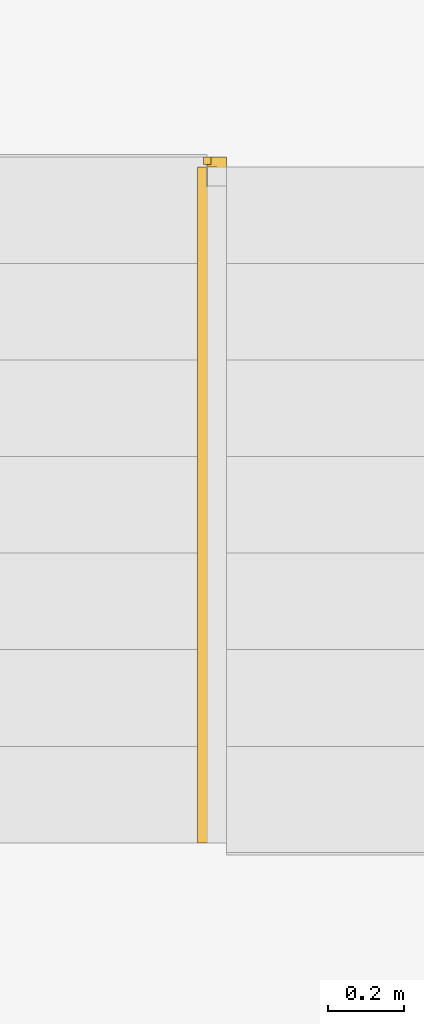
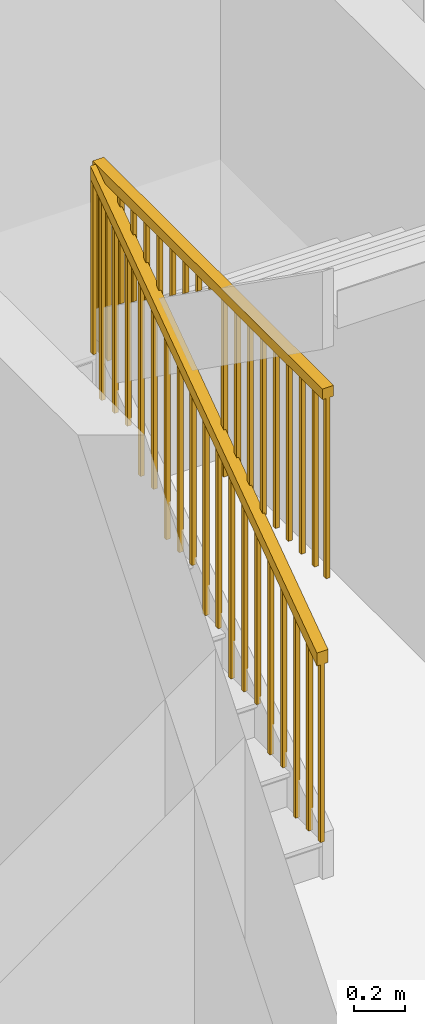
# One storey, part 5 of 6: 2 railings, 1 element without a shape of its own.
"""IFC2X3 building model written with IfcOpenShell, lengths in feet."""

import ifcopenshell
import ifcopenshell.guid

model = None  # the IFC model being written
_history = None  # IfcOwnerHistory: only IFC2X3 demands one
_inside = {}  # id of a spatial element -> (the spatial element, [elements in it])
_under = {}  # id of a project, library or spatial element -> (it, [spatial elements below it])
_declared = {}  # id of a project -> (the project, [libraries it declares])
_typed = {}  # id of a type object -> (the type object, [elements of that type])
_made_of = {}  # id of a material, layer set ... -> (it, [elements and type objects made of it])


def new_model(schema):
    """Start an empty IFC model of exactly this schema.

    Asked for "IFC4X3", IfcOpenShell would pick the latest addendum, in which some entities
    have other attributes; the version numbers below select the first issue.
    IFC2X3 requires an IfcOwnerHistory on every rooted entity: one is made here for all.
    """
    global model, _history
    if schema == "IFC4X3":
        model = ifcopenshell.file(schema_version=(4, 3, 0, 0))
    else:
        model = ifcopenshell.file(schema=schema)
    _inside.clear()
    _under.clear()
    _declared.clear()
    _typed.clear()
    _made_of.clear()
    _history = None
    if model.schema == "IFC2X3":
        org = make("IfcOrganization", Name="unknown")
        user = make(
            "IfcPersonAndOrganization",
            ThePerson=make("IfcPerson", FamilyName="unknown"),
            TheOrganization=org,
        )
        app = make(
            "IfcApplication",
            ApplicationDeveloper=org,
            Version="unknown",
            ApplicationFullName="unknown",
            ApplicationIdentifier="unknown",
        )
        _history = make(
            "IfcOwnerHistory",
            OwningUser=user,
            OwningApplication=app,
            ChangeAction="ADDED",
            CreationDate=0,
        )
    return model


def make(cls, **values):
    """One entity of the class cls with the attributes given. An attribute that is None is left unset."""
    return model.create_entity(
        cls, **{name: value for name, value in values.items() if value is not None}
    )


def entity(cls, *values):
    """Any entity or typed value of the class cls, its attributes in the order of the schema. None: left unset."""
    e = model.create_entity(cls)
    for i, value in enumerate(values):
        if value is not None:
            e[i] = value
    return e


def rooted(cls, **values):
    """An entity with a GlobalId (a new one), such as an element, a storey or a relation."""
    return make(cls, GlobalId=ifcopenshell.guid.new(), OwnerHistory=_history, **values)


def si_unit(unit_type, name, prefix=None):
    """IfcSIUnit, for example si_unit("LENGTHUNIT", "METRE", prefix="MILLI")."""
    return make("IfcSIUnit", UnitType=unit_type, Prefix=prefix, Name=name)


def converted_unit(unit_type, name, factor, base, dimensions=None, offset=None):
    """IfcConversionBasedUnit, such as the inch: factor (a typed value) times the base unit."""
    return make(
        "IfcConversionBasedUnit"
        if offset is None
        else "IfcConversionBasedUnitWithOffset",
        ConversionOffset=offset,
        Dimensions=None
        if dimensions is None
        else entity("IfcDimensionalExponents", *dimensions),
        UnitType=unit_type,
        Name=name,
        ConversionFactor=make(
            "IfcMeasureWithUnit", ValueComponent=factor, UnitComponent=base
        ),
    )


def derived_unit(unit_type, elements):
    """IfcDerivedUnit: a product of units, each with its exponent."""
    return make(
        "IfcDerivedUnit",
        Elements=[
            make("IfcDerivedUnitElement", Unit=unit, Exponent=power)
            for unit, power in elements
        ],
        UnitType=unit_type,
    )


def assignment(units):
    """IfcUnitAssignment: the units of a project."""
    return None if units is None else make("IfcUnitAssignment", Units=units)


def point(xyz):
    """IfcCartesianPoint."""
    return None if xyz is None else make("IfcCartesianPoint", Coordinates=xyz)


def direction(xyz):
    """IfcDirection."""
    return None if xyz is None else make("IfcDirection", DirectionRatios=xyz)


def frame(location, z_axis=None, x_axis=None):
    """IfcAxis2Placement3D, a coordinate frame: its origin and axes. An axis left out is left unset."""
    return make(
        "IfcAxis2Placement3D",
        Location=point(location),
        Axis=direction(z_axis),
        RefDirection=direction(x_axis),
    )


def frame_2d(location, x_axis=None):
    """IfcAxis2Placement2D, a coordinate frame in the plane: its origin and x axis."""
    return make(
        "IfcAxis2Placement2D", Location=point(location), RefDirection=direction(x_axis)
    )


def origin():
    """The frame at (0, 0, 0) with its axes left unset."""
    return frame((0.0, 0.0, 0.0))


def origin_2d_with_axis():
    """The frame at (0, 0) in the plane with the x axis (1, 0) written out."""
    return frame_2d((0.0, 0.0), x_axis=(1.0, 0.0))


def place(relative_to, where):
    """IfcLocalPlacement: puts the frame where relative to a parent placement (None: the world)."""
    return make(
        "IfcLocalPlacement", PlacementRelTo=relative_to, RelativePlacement=where
    )


def context(
    kind, dimensions, precision=None, world=None, true_north=None, identifier=None
):
    """IfcGeometricRepresentationContext, for example the 3D "Model" context."""
    return make(
        "IfcGeometricRepresentationContext",
        ContextIdentifier=identifier,
        ContextType=kind,
        CoordinateSpaceDimension=dimensions,
        Precision=precision,
        WorldCoordinateSystem=world,
        TrueNorth=true_north,
    )


def subcontext(parent, identifier, kind, view, scale=None):
    """IfcGeometricRepresentationSubContext, for example "Body" below "Model"."""
    return make(
        "IfcGeometricRepresentationSubContext",
        ContextIdentifier=identifier,
        ContextType=kind,
        ParentContext=parent,
        TargetScale=scale,
        TargetView=view,
    )


def project(units=None, contexts=None):
    """IfcProject with its units and contexts."""
    return rooted(
        "IfcProject",
        Name="project",
        RepresentationContexts=contexts,
        UnitsInContext=assignment(units),
    )


def spatial(cls, under=None, at=None, **own):
    """A site, building, storey or space (cls), placed at a placement, below another one or the project."""
    s = rooted(cls, ObjectPlacement=at, **own)
    if under is not None:
        _under.setdefault(under.id(), (under, []))[1].append(s)
    return s


def polyline(points):
    """IfcPolyline through the points."""
    return make("IfcPolyline", Points=[point(p) for p in points])


def profile(cls, at=None, kind="AREA", **sizes):
    """A parametric profile (cls). Its sizes go by their IFC names, for example OverallWidth=200.0."""
    return make(cls, ProfileType=kind, Position=at, **sizes)


def rectangle(**sizes):
    """IfcRectangleProfileDef."""
    return profile("IfcRectangleProfileDef", **sizes)


def outline(outer, holes=None, kind="AREA"):
    """IfcArbitraryClosedProfileDef: a profile drawn as a closed curve; with holes, ...WithVoids."""
    if holes is None:
        return make("IfcArbitraryClosedProfileDef", ProfileType=kind, OuterCurve=outer)
    return make(
        "IfcArbitraryProfileDefWithVoids",
        ProfileType=kind,
        OuterCurve=outer,
        InnerCurves=holes,
    )


def extrude(swept, where, along, depth):
    """IfcExtrudedAreaSolid: the profile swept, set in the frame where, extruded along a direction by depth."""
    return make(
        "IfcExtrudedAreaSolid",
        SweptArea=swept,
        Position=where,
        ExtrudedDirection=direction(along),
        Depth=depth,
    )


def shape(context_of_items, identifier, shape_type, items):
    """IfcShapeRepresentation: the items that make up one representation, for example the "Body"."""
    return make(
        "IfcShapeRepresentation",
        ContextOfItems=context_of_items,
        RepresentationIdentifier=identifier,
        RepresentationType=shape_type,
        Items=items,
    )


def material(Name=None, Category=None):
    """IfcMaterial."""
    return make("IfcMaterial", Name=Name, Category=Category)


def made_of(thing, what):
    """Note that an element or type object is made of a material, layer set ...; save() writes the relation."""
    if what is not None:
        _made_of.setdefault(what.id(), (what, []))[1].append(thing)
    return thing


def type_object(cls, material=None, **own):
    """A type object (cls), such as IfcWallType, which elements share."""
    return made_of(rooted(cls, **own), material)


def element(
    cls,
    number,
    at=None,
    inside=None,
    cuts=None,
    type_object=None,
    material=None,
    context=None,
    identifier="Body",
    shape_type=None,
    held_by="IfcProductDefinitionShape",
    body=None,
    shapes=None,
    **own,
):
    """One element of the class cls, such as IfcWall. Its Tag is "e" and its number.

    at: its placement. inside: the storey or other place that contains it. cuts: it is an
    opening in that element (IfcRelVoidsElement). A single representation is given by context,
    identifier, shape_type and body (its items); several are given by shapes. held_by: the class
    of the entity that holds the representations. save() writes the other relations.
    """
    e = rooted(cls, Tag="e%d" % number, ObjectPlacement=at, **own)
    if body is not None:
        shapes = [shape(context, identifier, shape_type, body)]
    if shapes is not None:
        e.Representation = make(held_by, Representations=shapes)
    if inside is not None:
        _inside.setdefault(inside.id(), (inside, []))[1].append(e)
    if cuts is not None:
        rooted(
            "IfcRelVoidsElement", RelatingBuildingElement=cuts, RelatedOpeningElement=e
        )
    if type_object is not None:
        _typed.setdefault(type_object.id(), (type_object, []))[1].append(e)
    return made_of(e, material)


def aggregate(whole, parts):
    """IfcRelAggregates: a whole, such as a stair, and the parts it consists of."""
    return rooted("IfcRelAggregates", RelatingObject=whole, RelatedObjects=parts)


def save(model, path):
    """Write the relations noted so far, then the file.

    IfcRelAggregates (storeys below a building ...), IfcRelContainedInSpatialStructure (elements
    in a storey), IfcRelDefinesByType, IfcRelAssociatesMaterial and IfcRelDeclares: one each for
    every whole, place, type object, material and project.
    """
    for whole, parts in _under.values():
        aggregate(whole, parts)
    for where, things in _inside.values():
        rooted(
            "IfcRelContainedInSpatialStructure",
            RelatedElements=things,
            RelatingStructure=where,
        )
    for kind, things in _typed.values():
        rooted("IfcRelDefinesByType", RelatedObjects=things, RelatingType=kind)
    for what, things in _made_of.values():
        rooted("IfcRelAssociatesMaterial", RelatedObjects=things, RelatingMaterial=what)
    for by, libraries in _declared.values():
        rooted("IfcRelDeclares", RelatingContext=by, RelatedDefinitions=libraries)
    model.write(path)


model = new_model("IFC2X3")

# Units and contexts
model_context = context("Model", 3, precision=0.0001, world=origin(), true_north=direction((6.123031769111886e-17, 1.0)))
body_context = subcontext(model_context, "Body", "Model", "MODEL_VIEW")
ifc_project = project(units=[converted_unit("LENGTHUNIT", "FOOT", entity("IfcLengthMeasure", 0.3048), si_unit("LENGTHUNIT", "METRE"), dimensions=[1, 0, 0, 0, 0, 0, 0]), converted_unit("AREAUNIT", "SQUARE FOOT", entity("IfcAreaMeasure", 0.09290304), si_unit("AREAUNIT", "SQUARE_METRE"), dimensions=[2, 0, 0, 0, 0, 0, 0]), converted_unit("VOLUMEUNIT", "CUBIC FOOT", entity("IfcVolumeMeasure", 0.028316846592000004), si_unit("VOLUMEUNIT", "CUBIC_METRE"), dimensions=[3, 0, 0, 0, 0, 0, 0]), converted_unit("PLANEANGLEUNIT", "DEGREE", entity("IfcPlaneAngleMeasure", 0.017453292519943278), si_unit("PLANEANGLEUNIT", "RADIAN"), dimensions=[0, 0, 0, 0, 0, 0, 0]), si_unit("MASSUNIT", "GRAM", prefix="KILO"), derived_unit("MASSDENSITYUNIT", [(si_unit("MASSUNIT", "GRAM", prefix="KILO"), 1), (si_unit("LENGTHUNIT", "METRE"), -3)]), derived_unit("IONCONCENTRATIONUNIT", [(si_unit("MASSUNIT", "GRAM", prefix="KILO"), 1), (si_unit("LENGTHUNIT", "METRE"), -3)]), derived_unit("MOMENTOFINERTIAUNIT", [(si_unit("LENGTHUNIT", "METRE"), 4)]), si_unit("TIMEUNIT", "SECOND"), si_unit("FREQUENCYUNIT", "HERTZ"), si_unit("THERMODYNAMICTEMPERATUREUNIT", "DEGREE_CELSIUS"), derived_unit("THERMALTRANSMITTANCEUNIT", [(si_unit("MASSUNIT", "GRAM", prefix="KILO"), 1), (si_unit("THERMODYNAMICTEMPERATUREUNIT", "KELVIN"), -1), (si_unit("TIMEUNIT", "SECOND"), -3)]), derived_unit("THERMALCONDUCTANCEUNIT", [(si_unit("MASSUNIT", "GRAM", prefix="KILO"), 1), (si_unit("THERMODYNAMICTEMPERATUREUNIT", "KELVIN"), -1), (si_unit("TIMEUNIT", "SECOND"), -3), (si_unit("LENGTHUNIT", "METRE"), 1)]), derived_unit("VOLUMETRICFLOWRATEUNIT", [(si_unit("LENGTHUNIT", "METRE"), 3), (si_unit("TIMEUNIT", "SECOND"), -1)]), derived_unit("MASSFLOWRATEUNIT", [(si_unit("MASSUNIT", "GRAM", prefix="KILO"), 1), (si_unit("TIMEUNIT", "SECOND"), -1)]), derived_unit("ROTATIONALFREQUENCYUNIT", [(si_unit("TIMEUNIT", "SECOND"), -1)]), si_unit("ELECTRICCURRENTUNIT", "AMPERE"), si_unit("ELECTRICVOLTAGEUNIT", "VOLT"), si_unit("POWERUNIT", "WATT"), converted_unit("FORCEUNIT", "KIP", entity("IfcForceMeasure", 2.088543423315013e-05), si_unit("FORCEUNIT", "NEWTON"), dimensions=[1, 1, -2, 0, 0, 0, 0]), si_unit("ILLUMINANCEUNIT", "LUX"), si_unit("LUMINOUSFLUXUNIT", "LUMEN"), si_unit("LUMINOUSINTENSITYUNIT", "CANDELA"), si_unit("ENERGYUNIT", "JOULE"), derived_unit("USERDEFINED", [(si_unit("MASSUNIT", "GRAM", prefix="KILO"), -1), (si_unit("LENGTHUNIT", "METRE"), -2), (si_unit("TIMEUNIT", "SECOND"), 3), (si_unit("LUMINOUSFLUXUNIT", "LUMEN"), 1)]), derived_unit("USERDEFINED", [(si_unit("MASSUNIT", "GRAM", prefix="KILO"), 1), (si_unit("TIMEUNIT", "SECOND"), -3), (si_unit("LENGTHUNIT", "METRE"), 3), (si_unit("ELECTRICCURRENTUNIT", "AMPERE"), -2)]), derived_unit("SOUNDPOWERUNIT", [(si_unit("MASSUNIT", "GRAM", prefix="KILO"), 1), (si_unit("TIMEUNIT", "SECOND"), -3), (si_unit("LENGTHUNIT", "METRE"), 2)]), derived_unit("SOUNDPRESSUREUNIT", [(si_unit("MASSUNIT", "GRAM", prefix="KILO"), 1), (si_unit("LENGTHUNIT", "METRE"), -1), (si_unit("TIMEUNIT", "SECOND"), -2)]), derived_unit("LINEARVELOCITYUNIT", [(si_unit("LENGTHUNIT", "METRE"), 1), (si_unit("TIMEUNIT", "SECOND"), -1)]), si_unit("PRESSUREUNIT", "PASCAL"), derived_unit("USERDEFINED", [(si_unit("MASSUNIT", "GRAM", prefix="KILO"), 1), (si_unit("LENGTHUNIT", "METRE"), -2), (si_unit("TIMEUNIT", "SECOND"), -2)]), derived_unit("LINEARFORCEUNIT", [(si_unit("MASSUNIT", "GRAM", prefix="KILO"), 1), (si_unit("TIMEUNIT", "SECOND"), -2)]), derived_unit("PLANARFORCEUNIT", [(si_unit("MASSUNIT", "GRAM", prefix="KILO"), 1), (si_unit("LENGTHUNIT", "METRE"), -1), (si_unit("TIMEUNIT", "SECOND"), -2)]), derived_unit("SPECIFICHEATCAPACITYUNIT", [(si_unit("THERMODYNAMICTEMPERATUREUNIT", "KELVIN"), -1), (si_unit("LENGTHUNIT", "METRE"), 2), (si_unit("TIMEUNIT", "SECOND"), -2)]), derived_unit("HEATFLUXDENSITYUNIT", [(si_unit("MASSUNIT", "GRAM", prefix="KILO"), 1), (si_unit("TIMEUNIT", "SECOND"), -3)]), derived_unit("HEATINGVALUEUNIT", [(si_unit("LENGTHUNIT", "METRE"), 2), (si_unit("TIMEUNIT", "SECOND"), -2)]), derived_unit("VAPORPERMEABILITYUNIT", [(si_unit("LENGTHUNIT", "METRE"), -1), (si_unit("TIMEUNIT", "SECOND"), 1)]), derived_unit("DYNAMICVISCOSITYUNIT", [(si_unit("MASSUNIT", "GRAM", prefix="KILO"), 1), (si_unit("TIMEUNIT", "SECOND"), -1), (si_unit("LENGTHUNIT", "METRE"), -1)]), derived_unit("THERMALEXPANSIONCOEFFICIENTUNIT", [(si_unit("THERMODYNAMICTEMPERATUREUNIT", "KELVIN"), -1)]), derived_unit("MODULUSOFELASTICITYUNIT", [(si_unit("MASSUNIT", "GRAM", prefix="KILO"), 1), (si_unit("LENGTHUNIT", "METRE"), -1), (si_unit("TIMEUNIT", "SECOND"), -2)]), derived_unit("ISOTHERMALMOISTURECAPACITYUNIT", [(si_unit("LENGTHUNIT", "METRE"), 3), (si_unit("MASSUNIT", "GRAM", prefix="KILO"), -1)]), derived_unit("MOISTUREDIFFUSIVITYUNIT", [(si_unit("TIMEUNIT", "SECOND"), -1), (si_unit("LENGTHUNIT", "METRE"), 2)]), derived_unit("MASSPERLENGTHUNIT", [(si_unit("MASSUNIT", "GRAM", prefix="KILO"), 1), (si_unit("LENGTHUNIT", "METRE"), -1)]), derived_unit("THERMALRESISTANCEUNIT", [(si_unit("MASSUNIT", "GRAM", prefix="KILO"), -1), (si_unit("TIMEUNIT", "SECOND"), 3), (si_unit("THERMODYNAMICTEMPERATUREUNIT", "KELVIN"), 1)]), derived_unit("ACCELERATIONUNIT", [(si_unit("LENGTHUNIT", "METRE"), 1), (si_unit("TIMEUNIT", "SECOND"), -2)]), derived_unit("ANGULARVELOCITYUNIT", [(si_unit("TIMEUNIT", "SECOND"), -1), (si_unit("PLANEANGLEUNIT", "RADIAN"), 1)]), derived_unit("LINEARSTIFFNESSUNIT", [(si_unit("MASSUNIT", "GRAM", prefix="KILO"), 1), (si_unit("TIMEUNIT", "SECOND"), -2)]), derived_unit("WARPINGCONSTANTUNIT", [(si_unit("LENGTHUNIT", "METRE"), 6)]), derived_unit("LINEARMOMENTUNIT", [(si_unit("MASSUNIT", "GRAM", prefix="KILO"), 1), (si_unit("LENGTHUNIT", "METRE"), 1), (si_unit("TIMEUNIT", "SECOND"), -2)]), derived_unit("TORQUEUNIT", [(si_unit("MASSUNIT", "GRAM", prefix="KILO"), 1), (si_unit("LENGTHUNIT", "METRE"), 2), (si_unit("TIMEUNIT", "SECOND"), -2)])], contexts=[model_context])

# Site, building, storey
site_placement = place(None, origin())
site = spatial("IfcSite", under=ifc_project, at=site_placement, CompositionType="ELEMENT")
building_placement = place(site_placement, origin())
building = spatial("IfcBuilding", under=site, at=building_placement, CompositionType="ELEMENT")
storey_placement = place(building_placement, origin())
storey = spatial("IfcBuildingStorey", under=building, at=storey_placement, Name="Level 1", CompositionType="ELEMENT", Elevation=0.0)

# Stair, railings
type_product = type_object("IfcTypeProduct")
stair_placement = place(storey_placement, origin())
stair = element("IfcStair", 1, at=stair_placement, inside=storey, type_object=type_product, Name="Assembled Stair:Stair", ShapeType="HALF_TURN_STAIR")
ifc_material = material()
railing_type = type_object("IfcRailingType", Name="Railing:Handrail - Rectangular", PredefinedType="NOTDEFINED")
railing_1_placement = place(stair_placement, origin())
railing_1 = element("IfcRailing", 2, at=railing_1_placement, type_object=railing_type, material=ifc_material, Name="Railing:Handrail - Rectangular", ObjectType="Railing:Handrail - Rectangular", PredefinedType="NOTDEFINED", context=body_context, shape_type="SweptSolid", body=[
    extrude(outline(polyline([(-1.6113254867989264, -0.03125), (1.6333957992989303, -0.03125), (1.6333957992989303, 0.03125), (-1.6554661117989342, 0.03125), (-1.6113254867989264, -0.03125)])), frame((-3.149496418584467, 12.833913631404993, 5.7531874659663265), z_axis=(1.0, 0.0, 0.0), x_axis=(0.0, 0.0, -1.0)), (0.0, 0.0, 1.0), 0.0625),
    extrude(outline(polyline([(-1.4936171534655713, -0.03125), (1.5156874659655761, -0.03125), (1.5156874659655761, 0.03125), (-1.5377577784655792, 0.03125), (-1.4936171534655713, -0.03125)])), frame((-3.1494964185844676, 12.500580298071661, 5.635479132632974), z_axis=(1.0, 0.0, 0.0), x_axis=(0.0, 0.0, -1.0)), (0.0, 0.0, 1.0), 0.0625),
    extrude(outline(polyline([(-1.3759088201322172, -0.03125), (1.3979791326322202, -0.03125), (1.3979791326322202, 0.03125), (-1.420049445132225, 0.03125), (-1.3759088201322172, -0.03125)])), frame((-3.149496418584468, 12.167246964738325, 5.517770799299618), z_axis=(1.0, 0.0, 0.0), x_axis=(0.0, 0.0, -1.0)), (0.0, 0.0, 1.0), 0.0625),
    extrude(outline(polyline([(-1.5524713201322493, -0.03125), (1.574541632632254, -0.03125), (1.5745416326322537, 0.03125), (-1.5966119451322571, 0.03125), (-1.5524713201322493, -0.03125)])), frame((-3.149496418584469, 11.833913631404993, 5.10579163263288), z_axis=(1.0, 0.0, 0.0), x_axis=(0.0, 0.0, -1.0)), (0.0, 0.0, 1.0), 0.0625),
    extrude(outline(polyline([(-1.4347629867988951, -0.03125), (1.4568332992988995, -0.03125), (1.4568332992988995, 0.03125), (-1.478903611798903, 0.03125), (-1.4347629867988951, -0.03125)])), frame((-3.1494964185844694, 11.500580298071661, 4.988083299299526), z_axis=(1.0, 0.0, 0.0), x_axis=(0.0, 0.0, -1.0)), (0.0, 0.0, 1.0), 0.0625),
    extrude(outline(polyline([(-1.6113254867989264, -0.03125), (1.6333957992989303, -0.03125), (1.6333957992989303, 0.03125), (-1.6554661117989342, 0.03125), (-1.6113254867989264, -0.03125)])), frame((-3.14949641858447, 11.167246964738327, 4.576104132632785), z_axis=(1.0, 0.0, 0.0), x_axis=(0.0, 0.0, -1.0)), (0.0, 0.0, 1.0), 0.0625),
    extrude(outline(polyline([(-1.4936171534655722, -0.03125), (1.5156874659655752, -0.03125), (1.5156874659655757, 0.03125), (-1.53775777846558, 0.03125), (-1.4936171534655722, -0.03125)])), frame((-3.1494964185844703, 10.833913631404993, 4.4583957992994305), z_axis=(1.0, 0.0, 0.0), x_axis=(0.0, 0.0, -1.0)), (0.0, 0.0, 1.0), 0.0625),
    extrude(outline(polyline([(-1.3759088201322172, -0.03125), (1.3979791326322206, -0.03125), (1.3979791326322206, 0.03125), (-1.420049445132225, 0.03125), (-1.3759088201322172, -0.03125)])), frame((-3.149496418584471, 10.500580298071661, 4.3406874659660755), z_axis=(1.0, 0.0, 0.0), x_axis=(0.0, 0.0, -1.0)), (0.0, 0.0, 1.0), 0.0625),
    extrude(outline(polyline([(-1.5524713201322493, -0.03125), (1.574541632632254, -0.03125), (1.5745416326322537, 0.03125), (-1.5966119451322571, 0.03125), (-1.5524713201322493, -0.03125)])), frame((-3.1494964185844716, 10.167246964738327, 3.9287082992993376), z_axis=(1.0, 0.0, 0.0), x_axis=(0.0, 0.0, -1.0)), (0.0, 0.0, 1.0), 0.0625),
    extrude(outline(polyline([(-1.4347629867988951, -0.03125), (1.4568332992988995, -0.03125), (1.4568332992988995, 0.03125), (-1.478903611798903, 0.03125), (-1.4347629867988951, -0.03125)])), frame((-3.149496418584472, 9.833913631404993, 3.8109999659659834), z_axis=(1.0, 0.0, 0.0), x_axis=(0.0, 0.0, -1.0)), (0.0, 0.0, 1.0), 0.0625),
    extrude(outline(polyline([(-1.6113254867989264, -0.03125), (1.6333957992989303, -0.03125), (1.6333957992989303, 0.03125), (-1.6554661117989342, 0.03125), (-1.6113254867989264, -0.03125)])), frame((-3.1494964185844725, 9.500580298071661, 3.399020799299243), z_axis=(1.0, 0.0, 0.0), x_axis=(0.0, 0.0, -1.0)), (0.0, 0.0, 1.0), 0.0625),
    extrude(outline(polyline([(-1.4936171534655722, -0.03125), (1.5156874659655752, -0.03125), (1.5156874659655757, 0.03125), (-1.53775777846558, 0.03125), (-1.4936171534655722, -0.03125)])), frame((-3.1494964185844734, 9.167246964738327, 3.2813124659658888), z_axis=(1.0, 0.0, 0.0), x_axis=(0.0, 0.0, -1.0)), (0.0, 0.0, 1.0), 0.0625),
    extrude(outline(polyline([(-1.3759088201322172, -0.03125), (1.3979791326322206, -0.03125), (1.3979791326322206, 0.03125), (-1.420049445132225, 0.03125), (-1.3759088201322172, -0.03125)])), frame((-3.149496418584474, 8.833913631404993, 3.1636041326325337), z_axis=(1.0, 0.0, 0.0), x_axis=(0.0, 0.0, -1.0)), (0.0, 0.0, 1.0), 0.0625),
    extrude(outline(polyline([(-1.5524713201322493, -0.03125), (1.574541632632254, -0.03125), (1.5745416326322537, 0.03125), (-1.5966119451322571, 0.03125), (-1.5524713201322493, -0.03125)])), frame((-3.1494964185844743, 8.500580298071661, 2.751624965965796), z_axis=(1.0, 0.0, 0.0), x_axis=(0.0, 0.0, -1.0)), (0.0, 0.0, 1.0), 0.0625),
    extrude(outline(polyline([(-1.4347629867988951, -0.03125), (1.4568332992988995, -0.03125), (1.4568332992988995, 0.03125), (-1.478903611798903, 0.03125), (-1.4347629867988951, -0.03125)])), frame((-3.1494964185844747, 8.167246964738327, 2.6339166326324417), z_axis=(1.0, 0.0, 0.0), x_axis=(0.0, 0.0, -1.0)), (0.0, 0.0, 1.0), 0.0625),
    extrude(outline(polyline([(-1.6113254867989268, -0.03125), (1.6333957992989303, -0.03125), (1.6333957992989303, 0.03125), (-1.6554661117989342, 0.03125), (-1.6113254867989268, -0.03125)])), frame((-3.1494964185844756, 7.833913631404994, 2.221937465965701), z_axis=(1.0, 0.0, 0.0), x_axis=(0.0, 0.0, -1.0)), (0.0, 0.0, 1.0), 0.0625),
    extrude(outline(polyline([(-1.4936171534655718, -0.03125), (1.5156874659655757, -0.03125), (1.5156874659655761, 0.03125), (-1.5377577784655796, 0.03125), (-1.4936171534655718, -0.03125)])), frame((-3.149496418584476, 7.50058029807166, 2.1042291326323475), z_axis=(1.0, 0.0, 0.0), x_axis=(0.0, 0.0, -1.0)), (0.0, 0.0, 1.0), 0.0625),
    extrude(outline(polyline([(-1.3943007472155564, -0.03125), (1.4163710597155612, -0.03125), (1.4163710597155612, 0.03125), (-1.4384413722155642, 0.03125), (-1.3943007472155564, -0.03125)])), frame((-3.1494964185844667, 13.052663631404993, 6.124704393049728), z_axis=(1.0, 0.0, 0.0), x_axis=(0.0, 0.0, -1.0)), (0.0, 0.0, 1.0), 0.0625),
    extrude(outline(polyline([(-1.3869439763822213, -0.03125), (1.4090142888822252, -0.03125), (1.4090142888822252, 0.03125), (-1.4310846013822291, 0.03125), (-1.3869439763822213, -0.03125)])), frame((-3.1494964185844765, 7.198496964738327, 1.9975559555489957), z_axis=(1.0, 0.0, 0.0), x_axis=(0.0, 0.0, -1.0)), (0.0, 0.0, 1.0), 0.0625),
    extrude(outline(polyline([(-3.6295845245388545, -0.08333333333333282), (3.5118761912055003, -0.08333333333333126), (3.629584524538854, 0.08333333333333481), (-3.5118761912055003, 0.0833333333333337), (-3.6295845245388545, -0.08333333333333282)])), frame((-3.201579751917805, 10.083913631404993, 5.546416632632694), z_axis=(1.0, 0.0, 0.0), x_axis=(0.0, 0.8168263560524708, 0.5768836139621599)), (0.0, 0.0, 1.0), 0.1666666666666665),
])
railing_2_placement = place(stair_placement, origin())
railing_2 = element("IfcRailing", 3, at=railing_2_placement, type_object=railing_type, material=ifc_material, Name="Railing:Handrail - Rectangular", ObjectType="Railing:Handrail - Rectangular", PredefinedType="NOTDEFINED", context=body_context, shape_type="SweptSolid", body=[
    extrude(outline(polyline([(-1.4053097341697978, -0.03125), (1.4273800466698026, -0.03125), (1.3832394216697947, 0.03125), (-1.4053097341697969, 0.03125), (-1.4053097341697978, -0.03125)])), frame((-3.0661630852511337, 12.833913631404993, 6.136356932497702), z_axis=(1.0, 0.0, 0.0), x_axis=(0.0, 0.0, -1.0)), (0.0, 0.0, 1.0), 0.0625),
    extrude(outline(polyline([(-0.875622234169704, -0.03125), (0.8535519216696992, -0.03125), (0.897692546669707, 0.03125), (-0.875622234169704, 0.03125), (-0.875622234169704, -0.03125)])), frame((-3.066163085251134, 12.500580298071661, 6.666044432497796), z_axis=(1.0, 0.0, 0.0), x_axis=(0.0, 0.0, -1.0)), (0.0, 0.0, 1.0), 0.0625),
    extrude(outline(polyline([(-0.757913900836348, -0.03125), (0.7358435883363441, -0.03125), (0.7799842133363519, 0.03125), (-0.757913900836348, 0.03125), (-0.757913900836348, -0.03125)])), frame((-3.0661630852511346, 12.167246964738325, 6.783752765831151), z_axis=(1.0, 0.0, 0.0), x_axis=(0.0, 0.0, -1.0)), (0.0, 0.0, 1.0), 0.0625),
    extrude(outline(polyline([(-0.6402055675029947, -0.03125), (0.6181352550029908, -0.03125), (0.6622758800029978, 0.03125), (-0.6402055675029947, 0.03125), (-0.6402055675029947, -0.03125)])), frame((-3.0661630852511355, 11.833913631404993, 6.9014610991645045), z_axis=(1.0, 0.0, 0.0), x_axis=(0.0, 0.0, -1.0)), (0.0, 0.0, 1.0), 0.0625),
    extrude(outline(polyline([(-0.5224972341696406, -0.03125), (0.5004269216696366, -0.03125), (0.5445675466696454, 0.03125), (-0.5224972341696406, 0.03125), (-0.5224972341696406, -0.03125)])), frame((-3.066163085251136, 11.500580298071661, 7.019169432497859), z_axis=(1.0, 0.0, 0.0), x_axis=(0.0, 0.0, -1.0)), (0.0, 0.0, 1.0), 0.0625),
    extrude(outline(polyline([(-0.4047889008362864, -0.03125), (0.3827185883362825, -0.03125), (0.4268592133362903, 0.03125), (-0.4047889008362864, 0.03125), (-0.4047889008362864, -0.03125)])), frame((-3.0661630852511363, 11.167246964738327, 7.136877765831213), z_axis=(1.0, 0.0, 0.0), x_axis=(0.0, 0.0, -1.0)), (0.0, 0.0, 1.0), 0.0625),
    extrude(outline(polyline([(-0.2870805675029322, -0.03125), (0.2650102550029292, -0.03125), (0.3091508800029361, 0.03125), (-0.2870805675029322, 0.03125), (-0.2870805675029322, -0.03125)])), frame((-3.066163085251137, 10.833913631404993, 7.254586099164568), z_axis=(1.0, 0.0, 0.0), x_axis=(0.0, 0.0, -1.0)), (0.0, 0.0, 1.0), 0.0625),
    extrude(outline(polyline([(-0.16937223416957892, -0.03125), (0.14730192166957412, -0.03125), (0.19144254666958194, 0.03125), (-0.16937223416957892, 0.03125), (-0.16937223416957892, -0.03125)])), frame((-3.0661630852511377, 10.500580298071661, 7.372294432497921), z_axis=(1.0, 0.0, 0.0), x_axis=(0.0, 0.0, -1.0)), (0.0, 0.0, 1.0), 0.0625),
    extrude(outline(polyline([(-0.05166390083622385, -0.03125), (0.029593588336219057, -0.03125), (0.07373421333622598, 0.03125), (-0.05166390083622385, 0.03125), (-0.05166390083622385, -0.03125)])), frame((-3.066163085251138, 10.167246964738327, 7.490002765831275), z_axis=(1.0, 0.0, 0.0), x_axis=(0.0, 0.0, -1.0)), (0.0, 0.0, 1.0), 0.0625),
    extrude(rectangle(XDim=0.0625, YDim=0.0625, at=origin_2d_with_axis()), frame((-3.0349130852511386, 9.833913631404993, 4.708333333334167), z_axis=(0.0, 0.0, 1.0), x_axis=(0.0, 1.0, 0.0)), (0.0, 0.0, 1.0), 2.833333333333332),
    extrude(rectangle(XDim=0.0625, YDim=0.0625, at=origin_2d_with_axis()), frame((-3.034913085251139, 9.500580298071661, 4.708333333334167), z_axis=(0.0, 0.0, 1.0), x_axis=(0.0, 1.0, 0.0)), (0.0, 0.0, 1.0), 2.833333333333332),
    extrude(rectangle(XDim=0.0625, YDim=0.0625, at=origin_2d_with_axis()), frame((-3.03491308525114, 9.167246964738327, 4.708333333334167), z_axis=(0.0, 0.0, 1.0), x_axis=(0.0, 1.0, 0.0)), (0.0, 0.0, 1.0), 2.833333333333332),
    extrude(rectangle(XDim=0.0625, YDim=0.0625, at=origin_2d_with_axis()), frame((-3.0349130852511403, 8.833913631404993, 4.708333333334167), z_axis=(0.0, 0.0, 1.0), x_axis=(0.0, 1.0, 0.0)), (0.0, 0.0, 1.0), 2.833333333333332),
    extrude(rectangle(XDim=0.0625, YDim=0.0625, at=origin_2d_with_axis()), frame((-3.034913085251141, 8.50058029807166, 4.708333333334167), z_axis=(0.0, 0.0, 1.0), x_axis=(0.0, 1.0, 0.0)), (0.0, 0.0, 1.0), 2.833333333333332),
    extrude(rectangle(XDim=0.0625, YDim=0.0625, at=origin_2d_with_axis()), frame((-3.0349130852511412, 8.167246964738327, 4.708333333334167), z_axis=(0.0, 0.0, 1.0), x_axis=(0.0, 1.0, 0.0)), (0.0, 0.0, 1.0), 2.833333333333332),
    extrude(rectangle(XDim=0.0625, YDim=0.0625, at=origin_2d_with_axis()), frame((-3.034913085251142, 7.833913631404994, 4.708333333334167), z_axis=(0.0, 0.0, 1.0), x_axis=(0.0, 1.0, 0.0)), (0.0, 0.0, 1.0), 2.833333333333332),
    extrude(rectangle(XDim=0.0625, YDim=0.0625, at=origin_2d_with_axis()), frame((-3.0349130852511426, 7.50058029807166, 4.708333333334167), z_axis=(0.0, 0.0, 1.0), x_axis=(0.0, 1.0, 0.0)), (0.0, 0.0, 1.0), 2.833333333333332),
    extrude(rectangle(XDim=0.0625, YDim=0.0625, at=origin_2d_with_axis()), frame((-3.0349130852511332, 13.05266363140501, 4.708333333334167), z_axis=(0.0, 0.0, 1.0), x_axis=(0.0, 1.0, 0.0)), (0.0, 0.0, 1.0), 2.833333333333332),
    extrude(rectangle(XDim=0.0625, YDim=0.0625, at=origin_2d_with_axis()), frame((-3.034913085251143, 7.198496964738327, 4.708333333334167), z_axis=(0.0, 0.0, 1.0), x_axis=(0.0, 1.0, 0.0)), (0.0, 0.0, 1.0), 2.833333333333332),
    extrude(rectangle(XDim=5.916666666666684, YDim=0.16666666666666652, at=frame_2d((8.881784197001252e-16, 2.220446049250313e-16), x_axis=(1.0, 0.0))), frame((-3.034913085251138, 10.125580298071668, 7.541666666667501), z_axis=(0.0, 0.0, 1.0), x_axis=(0.0, 1.0, 0.0)), (0.0, 0.0, 1.0), 0.16666666666666696),
])
aggregate(stair, [railing_1, railing_2])

save(model, "model.ifc")
